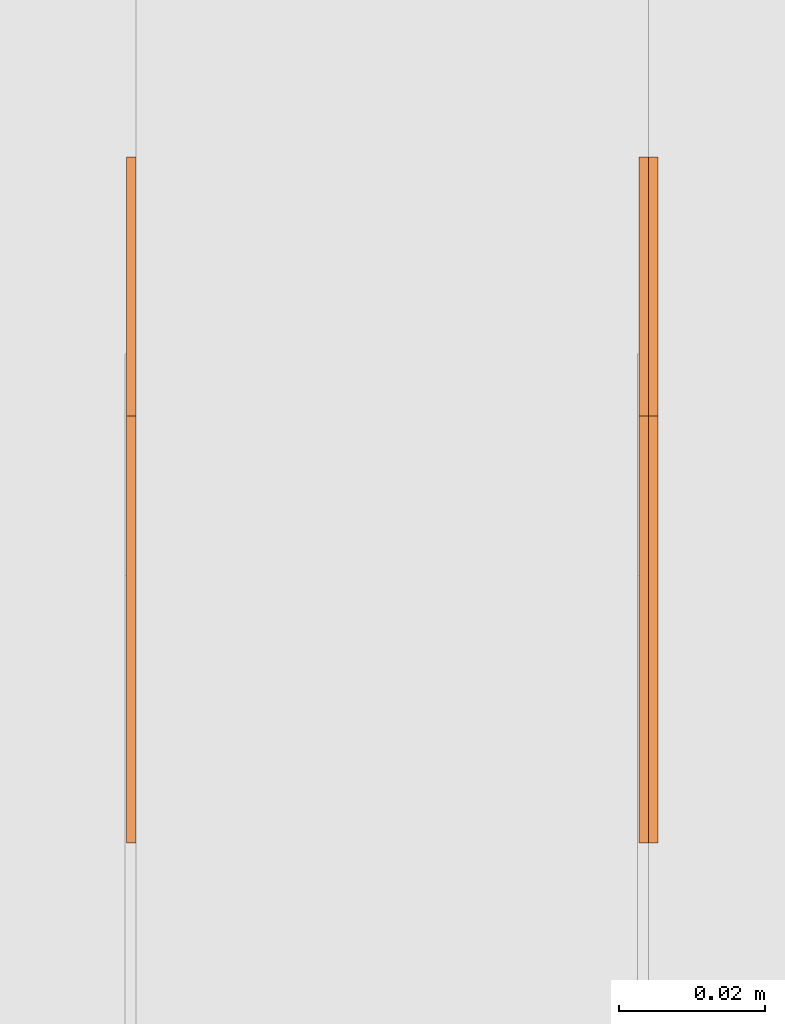
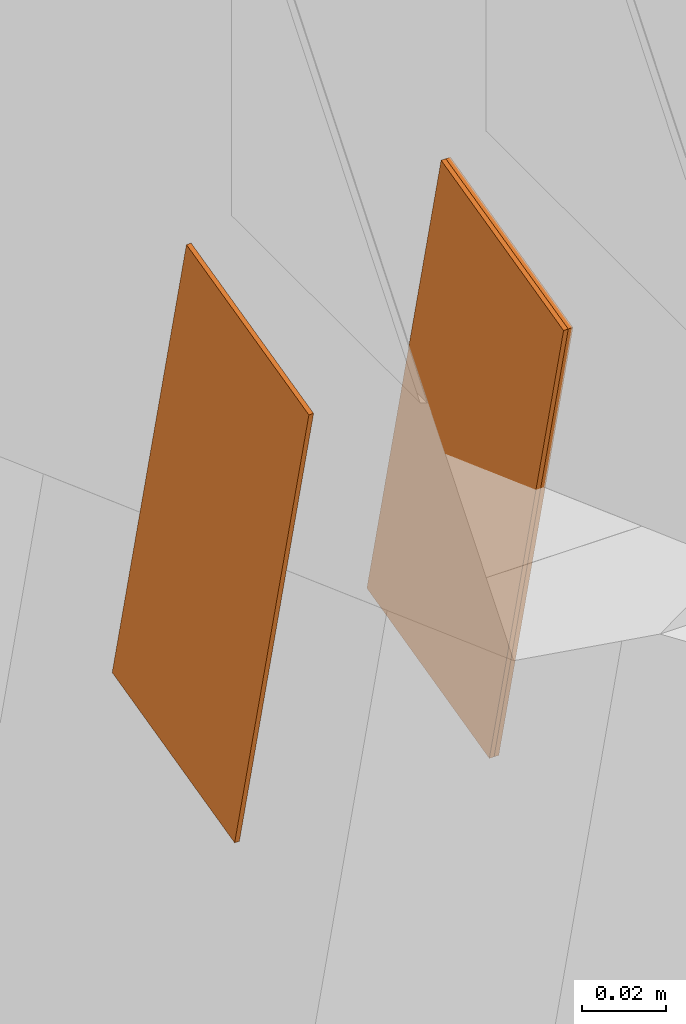
# One storey, part 152 of 189: 3 proxies.
"""IFC2X3 building model written with IfcOpenShell, lengths in millimetres."""

from ifc_helpers import new_model, entity, si_unit, converted_unit, derived_unit, direction, frame, origin, place, context, subcontext, project, spatial, polyline, outline, extrude, source, transform, mapped, material, type_object, type_shapes, element, save


model = new_model("IFC2X3")

# Units and contexts
model_context = context("Model", 3, precision=0.01, world=origin(), true_north=direction((6.12303176911189e-17, 1.0)))
body_context = subcontext(model_context, "Body", "Model", "MODEL_VIEW")
ifc_project = project(units=[si_unit("LENGTHUNIT", "METRE", prefix="MILLI"), si_unit("AREAUNIT", "SQUARE_METRE"), si_unit("VOLUMEUNIT", "CUBIC_METRE"), converted_unit("PLANEANGLEUNIT", "DEGREE", entity("IfcRatioMeasure", 0.0174532925199433), si_unit("PLANEANGLEUNIT", "RADIAN"), dimensions=[0, 0, 0, 0, 0, 0, 0]), si_unit("MASSUNIT", "GRAM", prefix="KILO"), derived_unit("MASSDENSITYUNIT", [(si_unit("MASSUNIT", "GRAM", prefix="KILO"), 1), (si_unit("LENGTHUNIT", "METRE"), -3)]), si_unit("TIMEUNIT", "SECOND"), si_unit("FREQUENCYUNIT", "HERTZ"), si_unit("THERMODYNAMICTEMPERATUREUNIT", "DEGREE_CELSIUS"), derived_unit("THERMALTRANSMITTANCEUNIT", [(si_unit("MASSUNIT", "GRAM", prefix="KILO"), 1), (si_unit("THERMODYNAMICTEMPERATUREUNIT", "KELVIN"), -1), (si_unit("TIMEUNIT", "SECOND"), -3)]), derived_unit("VOLUMETRICFLOWRATEUNIT", [(si_unit("LENGTHUNIT", "METRE"), 3), (si_unit("TIMEUNIT", "SECOND"), -1)]), si_unit("ELECTRICCURRENTUNIT", "AMPERE"), si_unit("ELECTRICVOLTAGEUNIT", "VOLT"), si_unit("POWERUNIT", "WATT"), si_unit("FORCEUNIT", "NEWTON"), si_unit("ILLUMINANCEUNIT", "LUX"), si_unit("LUMINOUSFLUXUNIT", "LUMEN"), si_unit("LUMINOUSINTENSITYUNIT", "CANDELA"), derived_unit("USERDEFINED", [(si_unit("MASSUNIT", "GRAM", prefix="KILO"), -1), (si_unit("LENGTHUNIT", "METRE"), -2), (si_unit("TIMEUNIT", "SECOND"), 3), (si_unit("LUMINOUSFLUXUNIT", "LUMEN"), 1)]), derived_unit("LINEARVELOCITYUNIT", [(si_unit("LENGTHUNIT", "METRE"), 1), (si_unit("TIMEUNIT", "SECOND"), -1)]), si_unit("PRESSUREUNIT", "PASCAL"), derived_unit("USERDEFINED", [(si_unit("LENGTHUNIT", "METRE"), -2), (si_unit("MASSUNIT", "GRAM", prefix="KILO"), 1), (si_unit("TIMEUNIT", "SECOND"), -2)])], contexts=[model_context])

# Site, building, storey
site_placement = place(None, origin())
site = spatial("IfcSite", under=ifc_project, at=site_placement, CompositionType="ELEMENT")
building_placement = place(site_placement, origin())
building = spatial("IfcBuilding", under=site, at=building_placement, CompositionType="ELEMENT")
storey_placement = place(building_placement, origin())
storey = spatial("IfcBuildingStorey", under=building, at=storey_placement, Name="Default", CompositionType="ELEMENT", Elevation=0.0)

# Proxies
ifc_material_1 = material(Name="IfcSurfaceStyle #251495")
building_element_proxy_type_1 = type_object("IfcBuildingElementProxyType", PredefinedType="NOTDEFINED", material=ifc_material_1)
shared_shape_1 = source(origin(), body_context, "Body", "SweptSolid", [
    extrude(outline(polyline([(-75.0000887866359, -29.9998989709511), (75.0001520611545, -29.9998989709511), (74.99985152006, 29.9998989709511), (-74.9999147945787, 29.9998989709511), (-75.0000887866359, -29.9998989709511)])), frame((75.0001520611545, 30.0001892337787, 0.0), z_axis=(0.0, 0.0, 1.0), x_axis=(-1.0, 0.0, 0.0)), (0.0, 0.0, 1.0), 1.29999999999999),
])
type_shapes(building_element_proxy_type_1, [shared_shape_1])
proxy_1_placement = place(building_placement, frame((45230.0, 14917.8195087731, 5530.89292927769), z_axis=(-1.0, 0.0, 0.0), x_axis=(0.0, 0.235625623344066, -0.971843899823279)))
element("IfcBuildingElementProxy", 1, at=proxy_1_placement, inside=storey, type_object=building_element_proxy_type_1, material=ifc_material_1, context=body_context, shape_type="MappedRepresentation", body=[
    mapped(shared_shape_1, transform((0.0, 0.0, 0.0), scale=1.0)),
])
ifc_material_2 = material(Name="IfcSurfaceStyle #251438")
building_element_proxy_type_2 = type_object("IfcBuildingElementProxyType", PredefinedType="NOTDEFINED", material=ifc_material_2)
shared_shape_2 = source(origin(), body_context, "Body", "SweptSolid", [
    extrude(outline(polyline([(-75.0000887866359, -29.9998989709511), (75.0001520611545, -29.9998989709511), (74.99985152006, 29.9998989709511), (-74.9999147945787, 29.9998989709511), (-75.0000887866359, -29.9998989709511)])), frame((75.0001520611545, 30.0001892337787, 0.0), z_axis=(0.0, 0.0, 1.0), x_axis=(-1.0, 0.0, 0.0)), (0.0, 0.0, 1.0), 1.29999999999999),
])
type_shapes(building_element_proxy_type_2, [shared_shape_2])
proxy_2_placement = place(building_placement, frame((45231.3, 14917.8195087731, 5530.89292927769), z_axis=(-1.0, 0.0, 0.0), x_axis=(0.0, 0.235625623344066, -0.971843899823279)))
element("IfcBuildingElementProxy", 2, at=proxy_2_placement, inside=storey, type_object=building_element_proxy_type_2, material=ifc_material_2, context=body_context, shape_type="MappedRepresentation", body=[
    mapped(shared_shape_2, transform((0.0, 0.0, 0.0), scale=1.0)),
])
ifc_material_3 = material(Name="IfcSurfaceStyle #251381")
building_element_proxy_type_3 = type_object("IfcBuildingElementProxyType", PredefinedType="NOTDEFINED", material=ifc_material_3)
shared_shape_3 = source(origin(), body_context, "Body", "SweptSolid", [
    extrude(outline(polyline([(-75.0000887866359, -29.9998989709511), (75.0001520611545, -29.9998989709511), (74.99985152006, 29.9998989709511), (-74.9999147945787, 29.9998989709511), (-75.0000887866359, -29.9998989709511)])), frame((75.0001520611545, 30.0001892337787, 0.0), z_axis=(0.0, 0.0, 1.0), x_axis=(-1.0, 0.0, 0.0)), (0.0, 0.0, 1.0), 1.29999999999999),
])
type_shapes(building_element_proxy_type_3, [shared_shape_3])
proxy_3_placement = place(building_placement, frame((45160.0, 14917.8195087731, 5530.89292927769), z_axis=(-1.0, 0.0, 0.0), x_axis=(0.0, 0.235625623344066, -0.971843899823279)))
element("IfcBuildingElementProxy", 3, at=proxy_3_placement, inside=storey, type_object=building_element_proxy_type_3, material=ifc_material_3, context=body_context, shape_type="MappedRepresentation", body=[
    mapped(shared_shape_3, transform((0.0, 0.0, 0.0), scale=1.0)),
])

save(model, "model.ifc")
